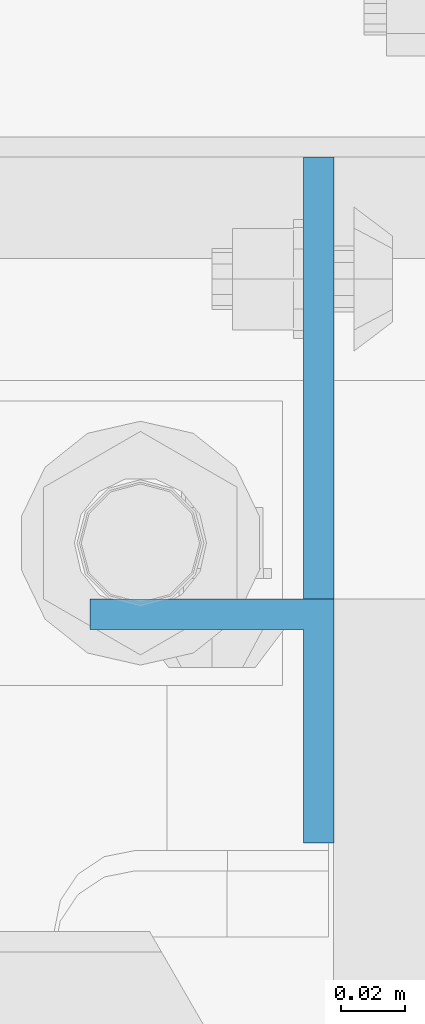
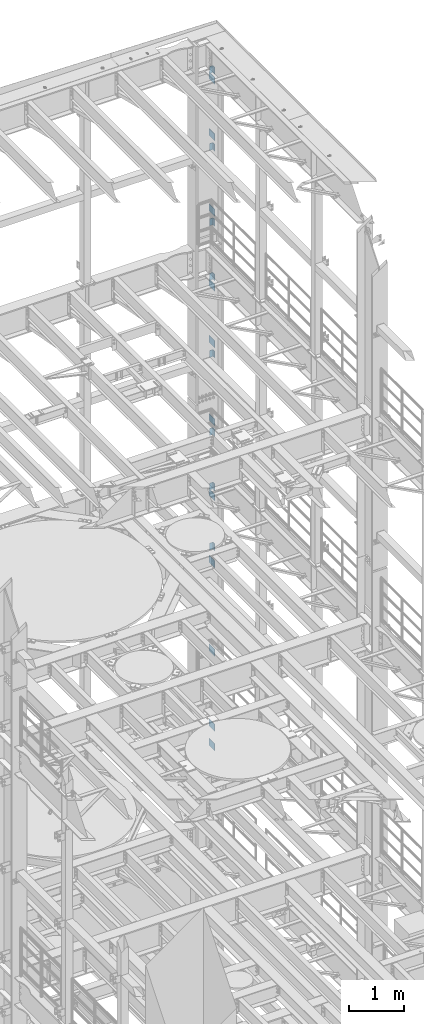
# One storey, part 1353 of 1876: 19 beams, 2 elements without a shape of their own.
"""IFC2X3 building model written with IfcOpenShell, lengths in millimetres."""

from ifc_helpers import new_model, si_unit, frame, origin_with_axes, place, context, subcontext, project, spatial, faceted_brep, material, type_object, element, aggregate, save


model = new_model("IFC2X3")

# Units and contexts
model_context = context("Model", 3, precision=1e-05, world=origin_with_axes())
body_context = subcontext(model_context, "Body", "Model", "MODEL_VIEW")
ifc_project = project(units=[si_unit("LENGTHUNIT", "METRE", prefix="MILLI"), si_unit("AREAUNIT", "SQUARE_METRE"), si_unit("VOLUMEUNIT", "CUBIC_METRE"), si_unit("MASSUNIT", "GRAM", prefix="KILO"), si_unit("TIMEUNIT", "SECOND"), si_unit("PLANEANGLEUNIT", "RADIAN"), si_unit("SOLIDANGLEUNIT", "STERADIAN"), si_unit("THERMODYNAMICTEMPERATUREUNIT", "DEGREE_CELSIUS"), si_unit("LUMINOUSINTENSITYUNIT", "LUMEN")], contexts=[model_context])

# Site, building, storey
site_placement = place(None, origin_with_axes())
site = spatial("IfcSite", under=ifc_project, at=site_placement, CompositionType="ELEMENT")
building_placement = place(site_placement, origin_with_axes())
building = spatial("IfcBuilding", under=site, at=building_placement, Name="Undefined", CompositionType="ELEMENT")
storey_placement = place(building_placement, origin_with_axes())
storey = spatial("IfcBuildingStorey", under=building, at=storey_placement, Name="Undefined", CompositionType="ELEMENT", Elevation=0.0)

# Assembly, beams
assembly_1_placement = place(storey_placement, origin_with_axes())
assembly_1 = element("IfcElementAssembly", 1, at=assembly_1_placement, inside=storey, Name="COLUMN", AssemblyPlace="NOTDEFINED", PredefinedType="RIGID_FRAME")
ifc_material = material(Name="STEEL/A36")
beam_type_1 = type_object("IfcBeamType", PredefinedType="NOTDEFINED")
beam_1_placement = place(assembly_1_placement, frame((7866.20421670226, 13800.1375001356, 21450.3), z_axis=(0.0, 0.0, -1.0), x_axis=(0.0, 1.0, 0.0)))
beam_1 = element("IfcBeam", 2, at=beam_1_placement, type_object=beam_type_1, material=ifc_material, Name="PLATE", context=body_context, shape_type="Brep", body=[
    faceted_brep([(0.0, 4.76249999999982, -76.1999999999998), (3.63797880709171e-12, 4.76249999999982, 76.1999969482422), (214.312499998445, 4.76249999993797, 76.2000000000007), (214.312499998445, 4.76249999993797, -76.2000000000007), (3.63797880709171e-12, -4.76249999999982, 76.1999969482422), (214.312499998441, -4.76250000006257, 76.2000000000007), (0.0, -4.76249999999982, -76.1999999999998), (214.312499998441, -4.76250000006257, -76.2000000000007)], [[[0, 1, 2, 3]], [[1, 4, 5, 2]], [[4, 6, 7, 5]], [[6, 0, 3, 7]], [[5, 7, 3, 2]], [[6, 4, 1, 0]]]),
])
beam_2_placement = place(assembly_1_placement, frame((7866.20421670226, 13800.1375001356, 20186.65), z_axis=(0.0, 0.0, -1.0), x_axis=(0.0, 1.0, 0.0)))
beam_2 = element("IfcBeam", 3, at=beam_2_placement, type_object=beam_type_1, material=ifc_material, Name="PLATE", context=body_context, shape_type="Brep", body=[
    faceted_brep([(0.0, 4.76249999999982, -76.1999999999998), (3.63797880709171e-12, 4.76249999999982, 76.1999969482422), (214.312499998445, 4.76249999993797, 76.2000000000007), (214.312499998445, 4.76249999993797, -76.2000000000007), (3.63797880709171e-12, -4.76249999999982, 76.1999969482422), (214.312499998441, -4.76250000006257, 76.2000000000007), (0.0, -4.76249999999982, -76.1999999999998), (214.312499998441, -4.76250000006257, -76.2000000000007)], [[[0, 1, 2, 3]], [[1, 4, 5, 2]], [[4, 6, 7, 5]], [[6, 0, 3, 7]], [[5, 7, 3, 2]], [[6, 4, 1, 0]]]),
])
beam_3_placement = place(assembly_1_placement, frame((7866.20421670226, 13800.1375001356, 18503.9), z_axis=(0.0, 0.0, -1.0), x_axis=(0.0, 1.0, 0.0)))
beam_3 = element("IfcBeam", 4, at=beam_3_placement, type_object=beam_type_1, material=ifc_material, Name="PLATE", context=body_context, shape_type="Brep", body=[
    faceted_brep([(0.0, 4.76249999999982, -76.1999999999998), (3.63797880709171e-12, 4.76249999999982, 76.1999969482422), (214.312499998445, 4.76249999993797, 76.2000000000007), (214.312499998445, 4.76249999993797, -76.2000000000007), (3.63797880709171e-12, -4.76249999999982, 76.1999969482422), (214.312499998441, -4.76250000006257, 76.2000000000007), (0.0, -4.76249999999982, -76.1999999999998), (214.312499998441, -4.76250000006257, -76.2000000000007)], [[[0, 1, 2, 3]], [[1, 4, 5, 2]], [[4, 6, 7, 5]], [[6, 0, 3, 7]], [[5, 7, 3, 2]], [[6, 4, 1, 0]]]),
])
beam_4_placement = place(assembly_1_placement, frame((7866.20421670226, 13800.1375001356, 16827.5), z_axis=(0.0, 0.0, -1.0), x_axis=(0.0, 1.0, 0.0)))
beam_4 = element("IfcBeam", 5, at=beam_4_placement, type_object=beam_type_1, material=ifc_material, Name="PLATE", context=body_context, shape_type="Brep", body=[
    faceted_brep([(0.0, 4.76249999999982, -76.1999999999998), (3.63797880709171e-12, 4.76249999999982, 76.1999969482422), (214.312499998445, 4.76249999993797, 76.2000000000007), (214.312499998445, 4.76249999993797, -76.2000000000007), (3.63797880709171e-12, -4.76249999999982, 76.1999969482422), (214.312499998441, -4.76250000006257, 76.2000000000007), (0.0, -4.76249999999982, -76.1999999999998), (214.312499998441, -4.76250000006257, -76.2000000000007)], [[[0, 1, 2, 3]], [[1, 4, 5, 2]], [[4, 6, 7, 5]], [[6, 0, 3, 7]], [[5, 7, 3, 2]], [[6, 4, 1, 0]]]),
])
beam_5_placement = place(assembly_1_placement, frame((7866.20421670226, 13800.1375001356, 15563.85), z_axis=(0.0, 0.0, -1.0), x_axis=(0.0, 1.0, 0.0)))
beam_5 = element("IfcBeam", 6, at=beam_5_placement, type_object=beam_type_1, material=ifc_material, Name="PLATE", context=body_context, shape_type="Brep", body=[
    faceted_brep([(0.0, 4.76249999999982, -76.1999999999998), (3.63797880709171e-12, 4.76249999999982, 76.1999969482422), (214.312499998445, 4.76249999993797, 76.2000000000007), (214.312499998445, 4.76249999993797, -76.2000000000007), (3.63797880709171e-12, -4.76249999999982, 76.1999969482422), (214.312499998441, -4.76250000006257, 76.2000000000007), (0.0, -4.76249999999982, -76.1999999999998), (214.312499998441, -4.76250000006257, -76.2000000000007)], [[[0, 1, 2, 3]], [[1, 4, 5, 2]], [[4, 6, 7, 5]], [[6, 0, 3, 7]], [[5, 7, 3, 2]], [[6, 4, 1, 0]]]),
])

assembly_2_placement = place(storey_placement, origin_with_axes())
assembly_2 = element("IfcElementAssembly", 7, at=assembly_2_placement, inside=storey, Name="COLUMN", AssemblyPlace="NOTDEFINED", PredefinedType="RIGID_FRAME")
beam_6_placement = place(assembly_2_placement, frame((7866.20421670226, 13800.1375001356, 13817.6), z_axis=(0.0, 0.0, -1.0), x_axis=(0.0, 1.0, 0.0)))
beam_6 = element("IfcBeam", 8, at=beam_6_placement, type_object=beam_type_1, material=ifc_material, Name="PLATE", context=body_context, shape_type="Brep", body=[
    faceted_brep([(0.0, 4.76249999999982, -76.1999999999998), (3.63797880709171e-12, 4.76249999999982, 76.1999969482422), (214.312499998445, 4.76249999993797, 76.2000000000007), (214.312499998445, 4.76249999993797, -76.2000000000007), (3.63797880709171e-12, -4.76249999999982, 76.1999969482422), (214.312499998441, -4.76250000006257, 76.2000000000007), (0.0, -4.76249999999982, -76.1999999999998), (214.312499998441, -4.76250000006257, -76.2000000000007)], [[[0, 1, 2, 3]], [[1, 4, 5, 2]], [[4, 6, 7, 5]], [[6, 0, 3, 7]], [[5, 7, 3, 2]], [[6, 4, 1, 0]]]),
])
beam_7_placement = place(assembly_2_placement, frame((7866.20421670226, 13800.1375001356, 12141.2), z_axis=(0.0, 0.0, -1.0), x_axis=(0.0, 1.0, 0.0)))
beam_7 = element("IfcBeam", 9, at=beam_7_placement, type_object=beam_type_1, material=ifc_material, Name="PLATE", context=body_context, shape_type="Brep", body=[
    faceted_brep([(0.0, 4.76249999999982, -76.1999999999998), (3.63797880709171e-12, 4.76249999999982, 76.1999969482422), (214.312499998445, 4.76249999993797, 76.2000000000007), (214.312499998445, 4.76249999993797, -76.2000000000007), (3.63797880709171e-12, -4.76249999999982, 76.1999969482422), (214.312499998441, -4.76250000006257, 76.2000000000007), (0.0, -4.76249999999982, -76.1999999999998), (214.312499998441, -4.76250000006257, -76.2000000000007)], [[[0, 1, 2, 3]], [[1, 4, 5, 2]], [[4, 6, 7, 5]], [[6, 0, 3, 7]], [[5, 7, 3, 2]], [[6, 4, 1, 0]]]),
])
beam_8_placement = place(assembly_2_placement, frame((7866.20421670226, 13800.1375001356, 10648.95), z_axis=(0.0, 0.0, -1.0), x_axis=(0.0, 1.0, 0.0)))
beam_8 = element("IfcBeam", 10, at=beam_8_placement, type_object=beam_type_1, material=ifc_material, Name="PLATE", context=body_context, shape_type="Brep", body=[
    faceted_brep([(0.0, 4.76249999999982, -76.1999999999998), (3.63797880709171e-12, 4.76249999999982, 76.1999969482422), (214.312499998445, 4.76249999993797, 76.2000000000007), (214.312499998445, 4.76249999993797, -76.2000000000007), (3.63797880709171e-12, -4.76249999999982, 76.1999969482422), (214.312499998441, -4.76250000006257, 76.2000000000007), (0.0, -4.76249999999982, -76.1999999999998), (214.312499998441, -4.76250000006257, -76.2000000000007)], [[[0, 1, 2, 3]], [[1, 4, 5, 2]], [[4, 6, 7, 5]], [[6, 0, 3, 7]], [[5, 7, 3, 2]], [[6, 4, 1, 0]]]),
])
beam_9_placement = place(assembly_2_placement, frame((7866.20421670226, 13800.1375001356, 8674.1), z_axis=(0.0, 0.0, -1.0), x_axis=(0.0, 1.0, 0.0)))
beam_9 = element("IfcBeam", 11, at=beam_9_placement, type_object=beam_type_1, material=ifc_material, Name="PLATE", context=body_context, shape_type="Brep", body=[
    faceted_brep([(0.0, 4.76249999999982, -76.1999999999998), (3.63797880709171e-12, 4.76249999999982, 76.1999969482422), (214.312499998445, 4.76249999993797, 76.2000000000007), (214.312499998445, 4.76249999993797, -76.2000000000007), (3.63797880709171e-12, -4.76249999999982, 76.1999969482422), (214.312499998441, -4.76250000006257, 76.2000000000007), (0.0, -4.76249999999982, -76.1999999999998), (214.312499998441, -4.76250000006257, -76.2000000000007)], [[[0, 1, 2, 3]], [[1, 4, 5, 2]], [[4, 6, 7, 5]], [[6, 0, 3, 7]], [[5, 7, 3, 2]], [[6, 4, 1, 0]]]),
])
beam_10_placement = place(assembly_2_placement, frame((7866.20421670226, 13800.1375001356, 6997.7), z_axis=(0.0, 0.0, -1.0), x_axis=(0.0, 1.0, 0.0)))
beam_10 = element("IfcBeam", 12, at=beam_10_placement, type_object=beam_type_1, material=ifc_material, Name="PLATE", context=body_context, shape_type="Brep", body=[
    faceted_brep([(0.0, 4.76249999999982, -76.1999999999998), (3.63797880709171e-12, 4.76249999999982, 76.1999969482422), (214.312499998445, 4.76249999993797, 76.2000000000007), (214.312499998445, 4.76249999993797, -76.2000000000007), (3.63797880709171e-12, -4.76249999999982, 76.1999969482422), (214.312499998441, -4.76250000006257, 76.2000000000007), (0.0, -4.76249999999982, -76.1999999999998), (214.312499998441, -4.76250000006257, -76.2000000000007)], [[[0, 1, 2, 3]], [[1, 4, 5, 2]], [[4, 6, 7, 5]], [[6, 0, 3, 7]], [[5, 7, 3, 2]], [[6, 4, 1, 0]]]),
])
beam_11_placement = place(assembly_2_placement, frame((7866.20421670226, 13800.1375001356, 6559.55), z_axis=(0.0, 0.0, -1.0), x_axis=(0.0, 1.0, 0.0)))
beam_11 = element("IfcBeam", 13, at=beam_11_placement, type_object=beam_type_1, material=ifc_material, Name="PLATE", context=body_context, shape_type="Brep", body=[
    faceted_brep([(0.0, 4.76249999999982, -76.1999999999998), (3.63797880709171e-12, 4.76249999999982, 76.1999969482422), (214.312499998445, 4.76249999993797, 76.2000000000007), (214.312499998445, 4.76249999993797, -76.2000000000007), (3.63797880709171e-12, -4.76249999999982, 76.1999969482422), (214.312499998441, -4.76250000006257, 76.2000000000007), (0.0, -4.76249999999982, -76.1999999999998), (214.312499998441, -4.76250000006257, -76.2000000000007)], [[[0, 1, 2, 3]], [[1, 4, 5, 2]], [[4, 6, 7, 5]], [[6, 0, 3, 7]], [[5, 7, 3, 2]], [[6, 4, 1, 0]]]),
])

# Beam
beam_type_2 = type_object("IfcBeamType", Name="L3X3X3/8", PredefinedType="NOTDEFINED")
beam_12_placement = place(assembly_1_placement, frame((7832.86671670226, 13838.2375, 21755.1), z_axis=(0.0, -1.0, 0.0), x_axis=(0.0, 0.0, -1.0)))
beam_12 = element("IfcBeam", 14, at=beam_12_placement, type_object=beam_type_2, material=ifc_material, Name="ANGLE", ObjectType="L3X3X3/8", context=body_context, shape_type="Brep", body=[
    faceted_brep([(0.0, 38.1000000000004, -38.1), (0.0, 38.1000000000004, 38.1), (152.4, 38.1000000000004, 38.1), (152.4, 38.1000000000004, -38.1), (0.0, 28.5749999999998, 38.1), (152.4, 28.5749999999998, 38.1), (0.0, 28.5749999999998, -28.575), (152.4, 28.5749999999998, -28.575), (0.0, -38.1000000000004, -28.575), (152.4, -38.1000000000004, -28.575), (0.0, -38.1000000000004, -38.1), (152.4, -38.1000000000004, -38.1)], [[[0, 1, 2, 3]], [[1, 4, 5, 2]], [[4, 6, 7, 5]], [[6, 8, 9, 7]], [[8, 10, 11, 9]], [[10, 0, 3, 11]], [[5, 7, 9, 11, 3, 2]], [[10, 8, 6, 4, 1, 0]]]),
])

beam_13_placement = place(assembly_1_placement, frame((7832.86671670226, 13838.2375, 20034.25), z_axis=(0.0, -1.0, 0.0), x_axis=(0.0, 0.0, -1.0)))
beam_13 = element("IfcBeam", 15, at=beam_13_placement, type_object=beam_type_2, material=ifc_material, Name="ANGLE", ObjectType="L3X3X3/8", context=body_context, shape_type="Brep", body=[
    faceted_brep([(0.0, 38.1000000000004, -38.1), (0.0, 38.1000000000004, 38.1), (152.4, 38.1000000000004, 38.1), (152.4, 38.1000000000004, -38.1), (0.0, 28.5749999999998, 38.1), (152.4, 28.5749999999998, 38.1), (0.0, 28.5749999999998, -28.575), (152.4, 28.5749999999998, -28.575), (0.0, -38.1000000000004, -28.575), (152.4, -38.1000000000004, -28.575), (0.0, -38.1000000000004, -38.1), (152.4, -38.1000000000004, -38.1)], [[[0, 1, 2, 3]], [[1, 4, 5, 2]], [[4, 6, 7, 5]], [[6, 8, 9, 7]], [[8, 10, 11, 9]], [[10, 0, 3, 11]], [[5, 7, 9, 11, 3, 2]], [[10, 8, 6, 4, 1, 0]]]),
])

beam_14_placement = place(assembly_1_placement, frame((7832.86671670226, 13838.2375, 18351.5), z_axis=(0.0, -1.0, 0.0), x_axis=(0.0, 0.0, -1.0)))
beam_14 = element("IfcBeam", 16, at=beam_14_placement, type_object=beam_type_2, material=ifc_material, Name="ANGLE", ObjectType="L3X3X3/8", context=body_context, shape_type="Brep", body=[
    faceted_brep([(0.0, 38.1000000000004, -38.1), (0.0, 38.1000000000004, 38.1), (152.4, 38.1000000000004, 38.1), (152.4, 38.1000000000004, -38.1), (0.0, 28.5749999999998, 38.1), (152.4, 28.5749999999998, 38.1), (0.0, 28.5749999999998, -28.575), (152.4, 28.5749999999998, -28.575), (0.0, -38.1000000000004, -28.575), (152.4, -38.1000000000004, -28.575), (0.0, -38.1000000000004, -38.1), (152.4, -38.1000000000004, -38.1)], [[[0, 1, 2, 3]], [[1, 4, 5, 2]], [[4, 6, 7, 5]], [[6, 8, 9, 7]], [[8, 10, 11, 9]], [[10, 0, 3, 11]], [[5, 7, 9, 11, 3, 2]], [[10, 8, 6, 4, 1, 0]]]),
])

beam_15_placement = place(assembly_1_placement, frame((7832.86671670226, 13838.2375, 17132.3), z_axis=(0.0, -1.0, 0.0), x_axis=(0.0, 0.0, -1.0)))
beam_15 = element("IfcBeam", 17, at=beam_15_placement, type_object=beam_type_2, material=ifc_material, Name="ANGLE", ObjectType="L3X3X3/8", context=body_context, shape_type="Brep", body=[
    faceted_brep([(0.0, 38.1000000000004, -38.1), (0.0, 38.1000000000004, 38.1), (152.4, 38.1000000000004, 38.1), (152.4, 38.1000000000004, -38.1), (0.0, 28.5749999999998, 38.1), (152.4, 28.5749999999998, 38.1), (0.0, 28.5749999999998, -28.575), (152.4, 28.5749999999998, -28.575), (0.0, -38.1000000000004, -28.575), (152.4, -38.1000000000004, -28.575), (0.0, -38.1000000000004, -38.1), (152.4, -38.1000000000004, -38.1)], [[[0, 1, 2, 3]], [[1, 4, 5, 2]], [[4, 6, 7, 5]], [[6, 8, 9, 7]], [[8, 10, 11, 9]], [[10, 0, 3, 11]], [[5, 7, 9, 11, 3, 2]], [[10, 8, 6, 4, 1, 0]]]),
])

beam_16_placement = place(assembly_1_placement, frame((7832.86671670226, 13838.2375, 15411.45), z_axis=(0.0, -1.0, 0.0), x_axis=(0.0, 0.0, -1.0)))
beam_16 = element("IfcBeam", 18, at=beam_16_placement, type_object=beam_type_2, material=ifc_material, Name="ANGLE", ObjectType="L3X3X3/8", context=body_context, shape_type="Brep", body=[
    faceted_brep([(0.0, 38.1000000000004, -38.1), (0.0, 38.1000000000004, 38.1), (152.4, 38.1000000000004, 38.1), (152.4, 38.1000000000004, -38.1), (0.0, 28.5749999999998, 38.1), (152.4, 28.5749999999998, 38.1), (0.0, 28.5749999999998, -28.575), (152.4, 28.5749999999998, -28.575), (0.0, -38.1000000000004, -28.575), (152.4, -38.1000000000004, -28.575), (0.0, -38.1000000000004, -38.1), (152.4, -38.1000000000004, -38.1)], [[[0, 1, 2, 3]], [[1, 4, 5, 2]], [[4, 6, 7, 5]], [[6, 8, 9, 7]], [[8, 10, 11, 9]], [[10, 0, 3, 11]], [[5, 7, 9, 11, 3, 2]], [[10, 8, 6, 4, 1, 0]]]),
])

aggregate(assembly_1, [beam_12, beam_13, beam_14, beam_15, beam_16, beam_1, beam_2, beam_3, beam_4, beam_5])

beam_17_placement = place(assembly_2_placement, frame((7832.86671670226, 13838.2375, 13665.2), z_axis=(0.0, -1.0, 0.0), x_axis=(0.0, 0.0, -1.0)))
beam_17 = element("IfcBeam", 19, at=beam_17_placement, type_object=beam_type_2, material=ifc_material, Name="ANGLE", ObjectType="L3X3X3/8", context=body_context, shape_type="Brep", body=[
    faceted_brep([(0.0, 38.1000000000004, -38.1), (0.0, 38.1000000000004, 38.1), (152.4, 38.1000000000004, 38.1), (152.4, 38.1000000000004, -38.1), (0.0, 28.5749999999998, 38.1), (152.4, 28.5749999999998, 38.1), (0.0, 28.5749999999998, -28.575), (152.4, 28.5749999999998, -28.575), (0.0, -38.1000000000004, -28.575), (152.4, -38.1000000000004, -28.575), (0.0, -38.1000000000004, -38.1), (152.4, -38.1000000000004, -38.1)], [[[0, 1, 2, 3]], [[1, 4, 5, 2]], [[4, 6, 7, 5]], [[6, 8, 9, 7]], [[8, 10, 11, 9]], [[10, 0, 3, 11]], [[5, 7, 9, 11, 3, 2]], [[10, 8, 6, 4, 1, 0]]]),
])

beam_18_placement = place(assembly_2_placement, frame((7832.86671670226, 13838.2375, 12446.0), z_axis=(0.0, -1.0, 0.0), x_axis=(0.0, 0.0, -1.0)))
beam_18 = element("IfcBeam", 20, at=beam_18_placement, type_object=beam_type_2, material=ifc_material, Name="ANGLE", ObjectType="L3X3X3/8", context=body_context, shape_type="Brep", body=[
    faceted_brep([(0.0, 38.1000000000004, -38.1), (0.0, 38.1000000000004, 38.1), (152.4, 38.1000000000004, 38.1), (152.4, 38.1000000000004, -38.1), (0.0, 28.5749999999998, 38.1), (152.4, 28.5749999999998, 38.1), (0.0, 28.5749999999998, -28.575), (152.4, 28.5749999999998, -28.575), (0.0, -38.1000000000004, -28.575), (152.4, -38.1000000000004, -28.575), (0.0, -38.1000000000004, -38.1), (152.4, -38.1000000000004, -38.1)], [[[0, 1, 2, 3]], [[1, 4, 5, 2]], [[4, 6, 7, 5]], [[6, 8, 9, 7]], [[8, 10, 11, 9]], [[10, 0, 3, 11]], [[5, 7, 9, 11, 3, 2]], [[10, 8, 6, 4, 1, 0]]]),
])

beam_19_placement = place(assembly_2_placement, frame((7832.86671670226, 13838.2375, 11106.15), z_axis=(0.0, -1.0, 0.0), x_axis=(0.0, 0.0, -1.0)))
beam_19 = element("IfcBeam", 21, at=beam_19_placement, type_object=beam_type_2, material=ifc_material, Name="ANGLE", ObjectType="L3X3X3/8", context=body_context, shape_type="Brep", body=[
    faceted_brep([(0.0, 38.1000000000004, -38.1), (0.0, 38.1000000000004, 38.1), (152.4, 38.1000000000004, 38.1), (152.4, 38.1000000000004, -38.1), (0.0, 28.5749999999998, 38.1), (152.4, 28.5749999999998, 38.1), (0.0, 28.5749999999998, -28.575), (152.4, 28.5749999999998, -28.575), (0.0, -38.1000000000004, -28.575), (152.4, -38.1000000000004, -28.575), (0.0, -38.1000000000004, -38.1), (152.4, -38.1000000000004, -38.1)], [[[0, 1, 2, 3]], [[1, 4, 5, 2]], [[4, 6, 7, 5]], [[6, 8, 9, 7]], [[8, 10, 11, 9]], [[10, 0, 3, 11]], [[5, 7, 9, 11, 3, 2]], [[10, 8, 6, 4, 1, 0]]]),
])

aggregate(assembly_2, [beam_17, beam_18, beam_19, beam_6, beam_7, beam_8, beam_9, beam_10, beam_11])

save(model, "model.ifc")
